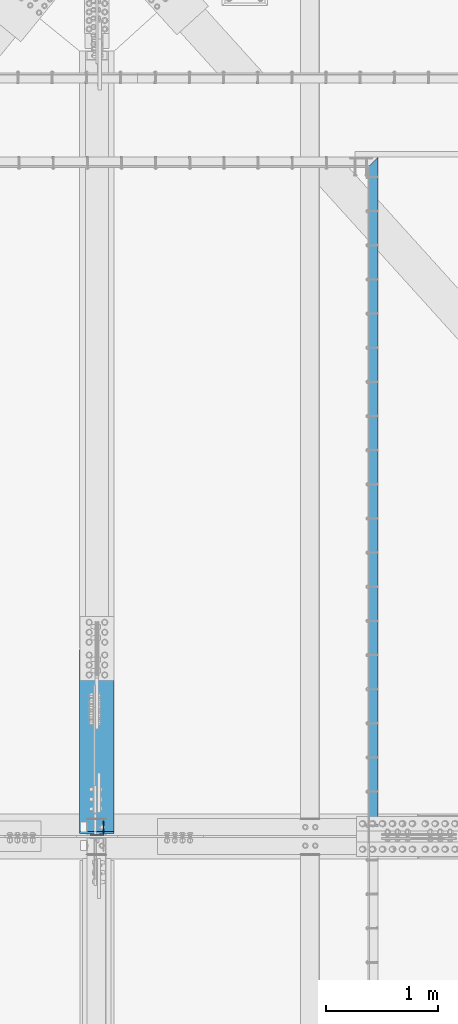
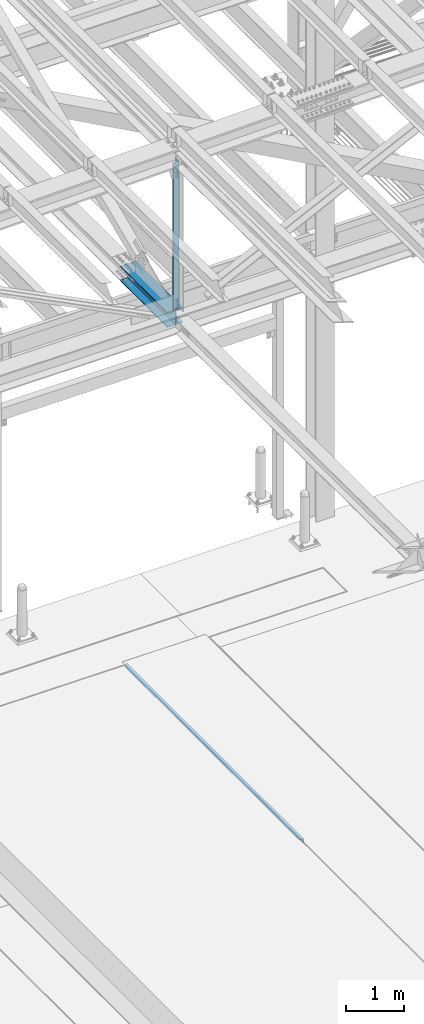
# One storey, part 1921 of 3843: 3 beams, 3 elements without a shape of their own.
"""IFC2X3 building model written with IfcOpenShell, lengths in millimetres."""

import ifcopenshell
import ifcopenshell.guid

model = None  # the IFC model being written
_history = None  # IfcOwnerHistory: only IFC2X3 demands one
_inside = {}  # id of a spatial element -> (the spatial element, [elements in it])
_under = {}  # id of a project, library or spatial element -> (it, [spatial elements below it])
_declared = {}  # id of a project -> (the project, [libraries it declares])
_typed = {}  # id of a type object -> (the type object, [elements of that type])
_made_of = {}  # id of a material, layer set ... -> (it, [elements and type objects made of it])


def new_model(schema):
    """Start an empty IFC model of exactly this schema.

    Asked for "IFC4X3", IfcOpenShell would pick the latest addendum, in which some entities
    have other attributes; the version numbers below select the first issue.
    IFC2X3 requires an IfcOwnerHistory on every rooted entity: one is made here for all.
    """
    global model, _history
    if schema == "IFC4X3":
        model = ifcopenshell.file(schema_version=(4, 3, 0, 0))
    else:
        model = ifcopenshell.file(schema=schema)
    _inside.clear()
    _under.clear()
    _declared.clear()
    _typed.clear()
    _made_of.clear()
    _history = None
    if model.schema == "IFC2X3":
        org = make("IfcOrganization", Name="unknown")
        user = make(
            "IfcPersonAndOrganization",
            ThePerson=make("IfcPerson", FamilyName="unknown"),
            TheOrganization=org,
        )
        app = make(
            "IfcApplication",
            ApplicationDeveloper=org,
            Version="unknown",
            ApplicationFullName="unknown",
            ApplicationIdentifier="unknown",
        )
        _history = make(
            "IfcOwnerHistory",
            OwningUser=user,
            OwningApplication=app,
            ChangeAction="ADDED",
            CreationDate=0,
        )
    return model


def make(cls, **values):
    """One entity of the class cls with the attributes given. An attribute that is None is left unset."""
    return model.create_entity(
        cls, **{name: value for name, value in values.items() if value is not None}
    )


def rooted(cls, **values):
    """An entity with a GlobalId (a new one), such as an element, a storey or a relation."""
    return make(cls, GlobalId=ifcopenshell.guid.new(), OwnerHistory=_history, **values)


def si_unit(unit_type, name, prefix=None):
    """IfcSIUnit, for example si_unit("LENGTHUNIT", "METRE", prefix="MILLI")."""
    return make("IfcSIUnit", UnitType=unit_type, Prefix=prefix, Name=name)


def assignment(units):
    """IfcUnitAssignment: the units of a project."""
    return None if units is None else make("IfcUnitAssignment", Units=units)


def point(xyz):
    """IfcCartesianPoint."""
    return None if xyz is None else make("IfcCartesianPoint", Coordinates=xyz)


def direction(xyz):
    """IfcDirection."""
    return None if xyz is None else make("IfcDirection", DirectionRatios=xyz)


def frame(location, z_axis=None, x_axis=None):
    """IfcAxis2Placement3D, a coordinate frame: its origin and axes. An axis left out is left unset."""
    return make(
        "IfcAxis2Placement3D",
        Location=point(location),
        Axis=direction(z_axis),
        RefDirection=direction(x_axis),
    )


def origin_with_axes():
    """The frame at (0, 0, 0) with the z axis (0, 0, 1) and the x axis (1, 0, 0) written out."""
    return frame((0.0, 0.0, 0.0), z_axis=(0.0, 0.0, 1.0), x_axis=(1.0, 0.0, 0.0))


def place(relative_to, where):
    """IfcLocalPlacement: puts the frame where relative to a parent placement (None: the world)."""
    return make(
        "IfcLocalPlacement", PlacementRelTo=relative_to, RelativePlacement=where
    )


def context(
    kind, dimensions, precision=None, world=None, true_north=None, identifier=None
):
    """IfcGeometricRepresentationContext, for example the 3D "Model" context."""
    return make(
        "IfcGeometricRepresentationContext",
        ContextIdentifier=identifier,
        ContextType=kind,
        CoordinateSpaceDimension=dimensions,
        Precision=precision,
        WorldCoordinateSystem=world,
        TrueNorth=true_north,
    )


def subcontext(parent, identifier, kind, view, scale=None):
    """IfcGeometricRepresentationSubContext, for example "Body" below "Model"."""
    return make(
        "IfcGeometricRepresentationSubContext",
        ContextIdentifier=identifier,
        ContextType=kind,
        ParentContext=parent,
        TargetScale=scale,
        TargetView=view,
    )


def project(units=None, contexts=None):
    """IfcProject with its units and contexts."""
    return rooted(
        "IfcProject",
        Name="project",
        RepresentationContexts=contexts,
        UnitsInContext=assignment(units),
    )


def spatial(cls, under=None, at=None, **own):
    """A site, building, storey or space (cls), placed at a placement, below another one or the project."""
    s = rooted(cls, ObjectPlacement=at, **own)
    if under is not None:
        _under.setdefault(under.id(), (under, []))[1].append(s)
    return s


def faces_of(points, faces, orient=None, outer=None):
    """IfcFace entities. A face is a list of loops; a loop is a list of indices into points, from 0.

    orient and outer hold one flag for each loop. By default every Orientation is true, the
    first loop of a face is its IfcFaceOuterBound and the others are IfcFaceBound.
    """
    made = []
    for i, loops in enumerate(faces):
        bounds = []
        for j, loop in enumerate(loops):
            is_outer = j == 0 if outer is None else outer[i][j]
            bounds.append(
                make(
                    "IfcFaceOuterBound" if is_outer else "IfcFaceBound",
                    Bound=make("IfcPolyLoop", Polygon=[points[k] for k in loop]),
                    Orientation=True if orient is None else orient[i][j],
                )
            )
        made.append(make("IfcFace", Bounds=bounds))
    return made


def faceted_brep(points, faces, orient=None, outer=None, voids=None):
    """IfcFacetedBrep: a solid bounded by flat faces; with voids (closed shells), ...WithVoids."""
    shared = [point(p) for p in points]
    hull = make("IfcClosedShell", CfsFaces=faces_of(shared, faces, orient, outer))
    if voids is None:
        return make("IfcFacetedBrep", Outer=hull)
    return make(
        "IfcFacetedBrepWithVoids",
        Outer=hull,
        Voids=[
            make(cls, CfsFaces=faces_of(shared, fs, o, b)) for cls, fs, o, b in voids
        ],
    )


def shape(context_of_items, identifier, shape_type, items):
    """IfcShapeRepresentation: the items that make up one representation, for example the "Body"."""
    return make(
        "IfcShapeRepresentation",
        ContextOfItems=context_of_items,
        RepresentationIdentifier=identifier,
        RepresentationType=shape_type,
        Items=items,
    )


def material(Name=None, Category=None):
    """IfcMaterial."""
    return make("IfcMaterial", Name=Name, Category=Category)


def made_of(thing, what):
    """Note that an element or type object is made of a material, layer set ...; save() writes the relation."""
    if what is not None:
        _made_of.setdefault(what.id(), (what, []))[1].append(thing)
    return thing


def type_object(cls, material=None, **own):
    """A type object (cls), such as IfcWallType, which elements share."""
    return made_of(rooted(cls, **own), material)


def element(
    cls,
    number,
    at=None,
    inside=None,
    cuts=None,
    type_object=None,
    material=None,
    context=None,
    identifier="Body",
    shape_type=None,
    held_by="IfcProductDefinitionShape",
    body=None,
    shapes=None,
    **own,
):
    """One element of the class cls, such as IfcWall. Its Tag is "e" and its number.

    at: its placement. inside: the storey or other place that contains it. cuts: it is an
    opening in that element (IfcRelVoidsElement). A single representation is given by context,
    identifier, shape_type and body (its items); several are given by shapes. held_by: the class
    of the entity that holds the representations. save() writes the other relations.
    """
    e = rooted(cls, Tag="e%d" % number, ObjectPlacement=at, **own)
    if body is not None:
        shapes = [shape(context, identifier, shape_type, body)]
    if shapes is not None:
        e.Representation = make(held_by, Representations=shapes)
    if inside is not None:
        _inside.setdefault(inside.id(), (inside, []))[1].append(e)
    if cuts is not None:
        rooted(
            "IfcRelVoidsElement", RelatingBuildingElement=cuts, RelatedOpeningElement=e
        )
    if type_object is not None:
        _typed.setdefault(type_object.id(), (type_object, []))[1].append(e)
    return made_of(e, material)


def aggregate(whole, parts):
    """IfcRelAggregates: a whole, such as a stair, and the parts it consists of."""
    return rooted("IfcRelAggregates", RelatingObject=whole, RelatedObjects=parts)


def save(model, path):
    """Write the relations noted so far, then the file.

    IfcRelAggregates (storeys below a building ...), IfcRelContainedInSpatialStructure (elements
    in a storey), IfcRelDefinesByType, IfcRelAssociatesMaterial and IfcRelDeclares: one each for
    every whole, place, type object, material and project.
    """
    for whole, parts in _under.values():
        aggregate(whole, parts)
    for where, things in _inside.values():
        rooted(
            "IfcRelContainedInSpatialStructure",
            RelatedElements=things,
            RelatingStructure=where,
        )
    for kind, things in _typed.values():
        rooted("IfcRelDefinesByType", RelatedObjects=things, RelatingType=kind)
    for what, things in _made_of.values():
        rooted("IfcRelAssociatesMaterial", RelatedObjects=things, RelatingMaterial=what)
    for by, libraries in _declared.values():
        rooted("IfcRelDeclares", RelatingContext=by, RelatedDefinitions=libraries)
    model.write(path)


model = new_model("IFC2X3")

# Units and contexts
model_context = context("Model", 3, precision=1e-05, world=origin_with_axes())
body_context = subcontext(model_context, "Body", "Model", "MODEL_VIEW")
ifc_project = project(units=[si_unit("LENGTHUNIT", "METRE", prefix="MILLI"), si_unit("AREAUNIT", "SQUARE_METRE"), si_unit("VOLUMEUNIT", "CUBIC_METRE"), si_unit("MASSUNIT", "GRAM", prefix="KILO"), si_unit("TIMEUNIT", "SECOND"), si_unit("PLANEANGLEUNIT", "RADIAN"), si_unit("SOLIDANGLEUNIT", "STERADIAN"), si_unit("THERMODYNAMICTEMPERATUREUNIT", "DEGREE_CELSIUS"), si_unit("LUMINOUSINTENSITYUNIT", "LUMEN")], contexts=[model_context])

# Site, building, storey
site_placement = place(None, origin_with_axes())
site = spatial("IfcSite", under=ifc_project, at=site_placement, CompositionType="ELEMENT")
building_placement = place(site_placement, origin_with_axes())
building = spatial("IfcBuilding", under=site, at=building_placement, Name="Undefined", CompositionType="ELEMENT")
storey_placement = place(building_placement, origin_with_axes())
storey = spatial("IfcBuildingStorey", under=building, at=storey_placement, Name="Undefined", CompositionType="ELEMENT", Elevation=0.0)

# Assembly, beam
assembly_1_placement = place(storey_placement, origin_with_axes())
assembly_1 = element("IfcElementAssembly", 1, at=assembly_1_placement, inside=storey, Name="EMBED_ANGLE", AssemblyPlace="NOTDEFINED", PredefinedType="RIGID_FRAME")
ifc_material_1 = material(Name="STEEL/A36")
beam_type_1 = type_object("IfcBeamType", Name="L3-1/2X3-1/2X5/16", PredefinedType="NOTDEFINED")
beam_1_placement = place(assembly_1_placement, frame((65101.0255556665, 83927.8222423303, 30410.15), z_axis=(0.0, 0.0, -1.0), x_axis=(-1.03669999999639e-05, 0.999999999946263, 0.0)))
beam_1 = element("IfcBeam", 2, at=beam_1_placement, type_object=beam_type_1, material=ifc_material_1, Name="EMBED_ANGLE", ObjectType="L3-1/2X3-1/2X5/16", context=body_context, shape_type="Brep", body=[
    faceted_brep([(-3.63797880709171e-12, 44.4499999999971, -44.4500000000007), (-3.63797880709171e-12, 44.4499999999971, 44.4500000000007), (6121.39999960882, 44.4499999836771, 44.4500000000007), (6121.39999960882, 44.4499999836771, -44.4500000000007), (-3.63797880709171e-12, 36.5124999999971, 44.4500000000007), (6113.46258133055, 36.5124999836698, 44.4500000000007), (-3.63797880709171e-12, 36.5124999999971, -36.5125000000007), (6113.46258133055, 36.5124999836698, -36.5125000000007), (3.63797880709171e-12, -44.4499999999971, -36.5125000000007), (6032.50091489223, -44.4500000163389, -36.5125000000007), (3.63797880709171e-12, -44.4499999999971, -44.4500000000007), (6032.50091489223, -44.4500000163389, -44.4500000000007)], [[[0, 1, 2, 3]], [[1, 4, 5, 2]], [[4, 6, 7, 5]], [[6, 8, 9, 7]], [[8, 10, 11, 9]], [[10, 0, 3, 11]], [[5, 7, 9, 11, 3, 2]], [[10, 8, 6, 4, 1, 0]]]),
])
aggregate(assembly_1, [beam_1])

assembly_2_placement = place(storey_placement, origin_with_axes())
assembly_2 = element("IfcElementAssembly", 3, at=assembly_2_placement, inside=storey, Name="BEAM", AssemblyPlace="NOTDEFINED", PredefinedType="RIGID_FRAME")
ifc_material_2 = material(Name="STEEL/A992")
beam_type_2 = type_object("IfcBeamType", Name="W12X79", PredefinedType="NOTDEFINED")
beam_2_placement = place(assembly_2_placement, frame((62636.3999983394, 83985.0999999778, 42259.1323511586), z_axis=(0.0, 0.001528912000329, 0.999998831213365), x_axis=(0.0, 0.999998831213365, -0.00152891200032518)))
beam_2 = element("IfcBeam", 4, at=beam_2_placement, type_object=beam_type_2, material=ifc_material_2, Name="BEAM", ObjectType="W12X79", context=body_context, shape_type="Brep", body=[
    faceted_brep([(19.6034623629675, 6.34999999999854, -131.762499999742), (6.90346236297046, -6.34999999999854, -119.0624999996), (6.90346236467303, -6.34999999999854, 119.062499999411), (19.6034623648302, 6.34999999999854, 131.762499999335), (25.9534623628861, 6.34999999999854, -138.112499999756), (25.9534623628861, 153.987500000003, -138.112499999756), (45.0034623631364, 153.987500000003, -157.162499999686), (45.0034623631364, -153.987500000003, -157.162499999089), (25.9534623628861, -153.987500000003, -138.112499999756), (25.9534623628861, -6.34999999999854, -138.112499999756), (1670.05195940222, -153.987500000003, 138.112500003183), (1670.05195940234, -153.987500000003, 157.162500003149), (45.0034623651591, -153.987500000003, 157.162499999613), (25.9534623654909, -153.987500000003, 138.112499999865), (1670.05195940234, 153.987500000003, 157.162500003149), (45.0034623651591, 153.987500000003, 157.162499999882), (1670.05195940222, 153.987500000003, 138.112500003183), (25.9534623654909, 153.987500000003, 138.112499999865), (1670.05195940222, 6.34999999999854, 138.112500003183), (25.9534623654909, 6.34999999999854, 138.112499999865), (25.9534623654909, -6.34999999999854, 138.112499999865), (1670.05195940222, -6.34999999999854, 138.112500003183), (1670.0519594002, 6.34999999999854, -138.112499996445), (1670.0519594002, -6.34999999999854, -138.112499996445), (1670.0519594002, -153.987500000003, -138.112499996445), (1670.05195940005, -153.987500000003, -157.162499996419), (1670.05195940005, 153.987500000003, -157.162499996419), (1670.0519594002, 153.987500000003, -138.112499996445)], [[[0, 1, 2, 3]], [[4, 5, 6, 7, 8, 9, 1, 0]], [[10, 11, 12, 13]], [[11, 14, 15, 12]], [[14, 16, 17, 15]], [[16, 18, 19, 17]], [[20, 13, 12, 15, 17, 19, 3, 2]], [[21, 10, 13, 20]], [[22, 18, 16, 14, 11, 10, 21, 23, 24, 25, 26, 27]], [[26, 25, 7, 6]], [[27, 26, 6, 5]], [[22, 27, 5, 4]], [[19, 18, 22, 4, 0, 3]], [[23, 21, 20, 2, 1, 9]], [[24, 23, 9, 8]], [[25, 24, 8, 7]]]),
])
aggregate(assembly_2, [beam_2])

assembly_3_placement = place(storey_placement, origin_with_axes())
assembly_3 = element("IfcElementAssembly", 5, at=assembly_3_placement, inside=storey, Name="ANGLE", AssemblyPlace="NOTDEFINED", PredefinedType="RIGID_FRAME")
ifc_material_3 = material(Name="STEEL/A572-50")
beam_type_3 = type_object("IfcBeamType", Name="L5X5X3/8", PredefinedType="NOTDEFINED")
beam_3_placement = place(assembly_3_placement, frame((62636.4, 84058.125, 45785.4080578587), z_axis=(-1.0, 0.0, 0.0), x_axis=(0.0, 0.0, -1.0)))
beam_3 = element("IfcBeam", 6, at=beam_3_placement, type_object=beam_type_3, material=ifc_material_3, Name="ANGLE", ObjectType="L5X5X3/8", context=body_context, shape_type="Brep", body=[
    faceted_brep([(223.676125720856, 63.5, -63.500000000713), (223.676125847858, 63.5, 63.499999999287), (3316.63774451319, 63.5, 63.5), (3316.63774451319, 63.5, -63.5), (223.676125847858, 53.9749999999985, 63.499999999287), (3316.63774451319, 53.9750000000058, 63.5), (223.676125730388, 53.9749999999985, -53.9750000007189), (3316.63774451319, 53.9750000000058, -53.9749999999985), (223.676125730388, -63.5, -53.9750000007189), (3316.63774451319, -63.5, -53.9749999999985), (223.676125720856, -63.5, -63.500000000713), (3316.63774451319, -63.5, -63.5)], [[[0, 1, 2, 3]], [[1, 4, 5, 2]], [[4, 6, 7, 5]], [[6, 8, 9, 7]], [[8, 10, 11, 9]], [[10, 0, 3, 11]], [[5, 7, 9, 11, 3, 2]], [[10, 8, 6, 4, 1, 0]]]),
])
aggregate(assembly_3, [beam_3])

save(model, "model.ifc")
